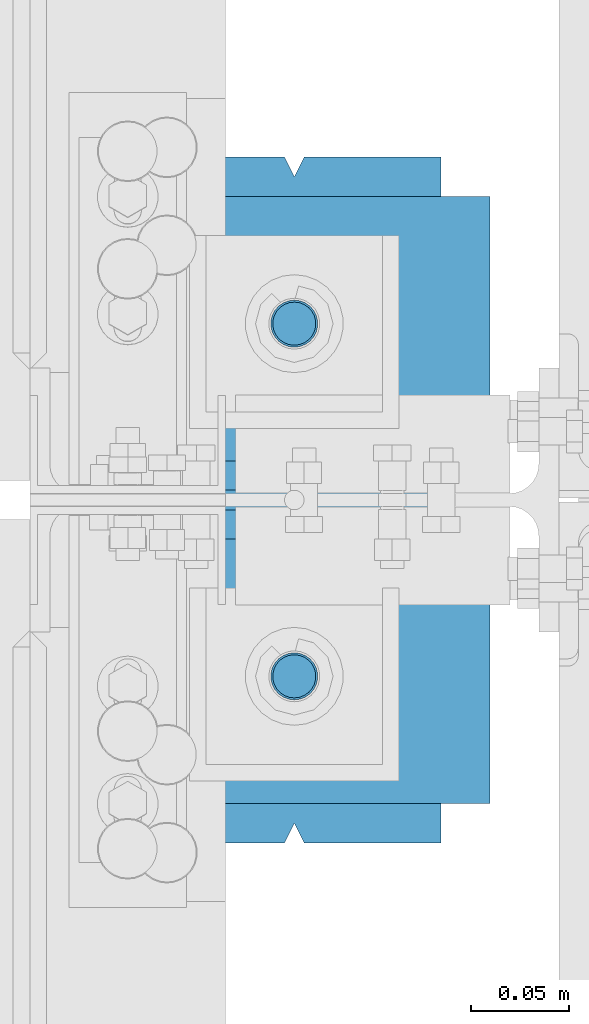
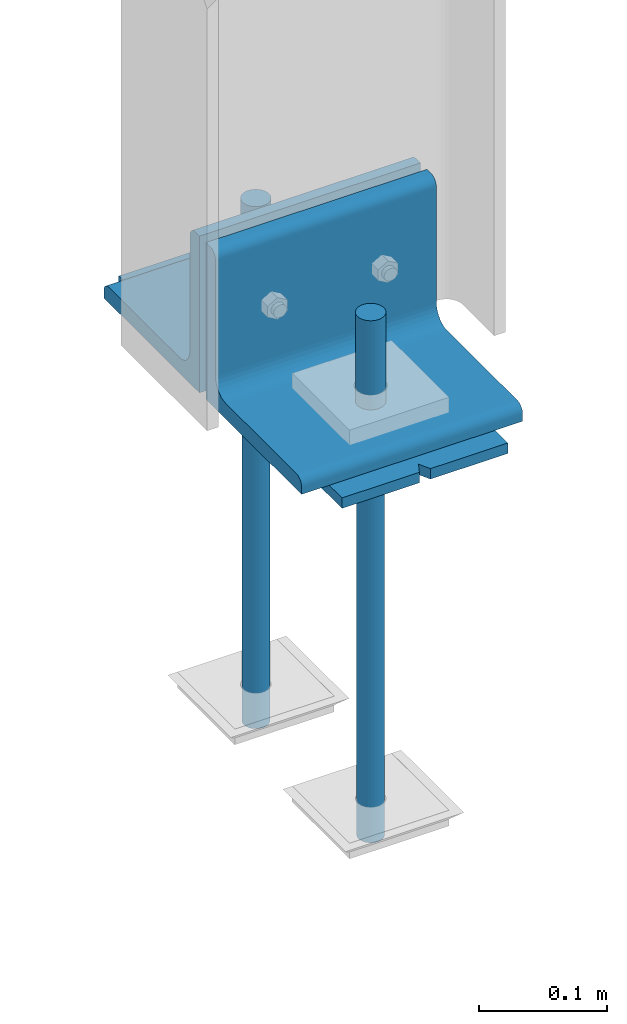
# One storey, part 73 of 496: 7 beams, 3 elements without a shape of their own.
"""IFC2X3 building model written with IfcOpenShell, lengths in millimetres."""

from ifc_helpers import new_model, si_unit, frame, origin_with_axes, origin_2d_with_axis, place, context, subcontext, project, spatial, polyline, rectangle, circle, l_section, outline, extrude, boolean, material, type_object, element, aggregate, save


model = new_model("IFC2X3")

# Units and contexts
model_context = context("Model", 3, precision=1e-05, world=origin_with_axes())
body_context = subcontext(model_context, "Body", "Model", "MODEL_VIEW")
ifc_project = project(units=[si_unit("LENGTHUNIT", "METRE", prefix="MILLI"), si_unit("AREAUNIT", "SQUARE_METRE"), si_unit("VOLUMEUNIT", "CUBIC_METRE"), si_unit("MASSUNIT", "GRAM", prefix="KILO"), si_unit("TIMEUNIT", "SECOND"), si_unit("PLANEANGLEUNIT", "RADIAN"), si_unit("SOLIDANGLEUNIT", "STERADIAN"), si_unit("THERMODYNAMICTEMPERATUREUNIT", "DEGREE_CELSIUS"), si_unit("LUMINOUSINTENSITYUNIT", "LUMEN")], contexts=[model_context])

# Site, building, storey
site_placement = place(None, origin_with_axes())
site = spatial("IfcSite", under=ifc_project, at=site_placement, CompositionType="ELEMENT")
building_placement = place(site_placement, origin_with_axes())
building = spatial("IfcBuilding", under=site, at=building_placement, Name="Undefined", CompositionType="ELEMENT")
storey_placement = place(building_placement, origin_with_axes())
storey = spatial("IfcBuildingStorey", under=building, at=storey_placement, Name="Undefined", CompositionType="ELEMENT", Elevation=0.0)

# Assembly, beams
assembly_1_placement = place(storey_placement, origin_with_axes())
assembly_1 = element("IfcElementAssembly", 1, at=assembly_1_placement, inside=storey, Name="PS24", AssemblyPlace="NOTDEFINED", PredefinedType="NOTDEFINED")
ifc_material = material(Name="Undefined/S235-E24")
beam_type_1 = type_object("IfcBeamType", Name="D24", PredefinedType="NOTDEFINED")
beam_1_placement = place(assembly_1_placement, frame((-45.0, 7509.99715044471, -100.0), z_axis=(-1.0, 0.0, 0.0), x_axis=(0.0, 0.0, -1.0)))
beam_1 = element("IfcBeam", 2, at=beam_1_placement, type_object=beam_type_1, material=ifc_material, ObjectType="D24", context=body_context, shape_type="SweptSolid", body=[
    extrude(circle(Radius=12.0, at=origin_2d_with_axis()), frame((149.999995982835, 4.54747350886464e-12, 3.63797880709171e-12), z_axis=(-1.0, 0.0, 0.0), x_axis=(0.0, -1.0, 0.0)), (0.0, 0.0, 1.0), 150.0),
])
beam_2_placement = place(assembly_1_placement, frame((-45.0, 7689.99715044471, -100.0), z_axis=(-1.0, 0.0, 0.0), x_axis=(0.0, 0.0, -1.0)))
beam_2 = element("IfcBeam", 3, at=beam_2_placement, type_object=beam_type_1, material=ifc_material, ObjectType="D24", context=body_context, shape_type="SweptSolid", body=[
    extrude(circle(Radius=12.0, at=origin_2d_with_axis()), frame((149.999995982835, 4.54747350886464e-12, 3.63797880709171e-12), z_axis=(-1.0, 0.0, 0.0), x_axis=(0.0, -1.0, 0.0)), (0.0, 0.0, 1.0), 150.0),
])
beam_type_2 = type_object("IfcBeamType", Name="D22", PredefinedType="NOTDEFINED")
beam_3_placement = place(assembly_1_placement, frame((-45.0, 7509.99715044471, -250.0), z_axis=(-1.0, 0.0, 0.0), x_axis=(0.0, 0.0, -1.0)))
beam_3 = element("IfcBeam", 4, at=beam_3_placement, type_object=beam_type_2, material=ifc_material, ObjectType="D22", context=body_context, shape_type="SweptSolid", body=[
    extrude(circle(Radius=11.0, at=origin_2d_with_axis()), frame((350.0, 0.0, 0.0), z_axis=(-1.0, 0.0, 0.0), x_axis=(0.0, -1.0, 0.0)), (0.0, 0.0, 1.0), 350.0),
])
beam_4_placement = place(assembly_1_placement, frame((-45.0, 7689.99715044471, -250.0), z_axis=(-1.0, 0.0, 0.0), x_axis=(0.0, 0.0, -1.0)))
beam_4 = element("IfcBeam", 5, at=beam_4_placement, type_object=beam_type_2, material=ifc_material, ObjectType="D22", context=body_context, shape_type="SweptSolid", body=[
    extrude(circle(Radius=11.0, at=origin_2d_with_axis()), frame((350.0, 0.0, 0.0), z_axis=(-1.0, 0.0, 0.0), x_axis=(0.0, -1.0, 0.0)), (0.0, 0.0, 1.0), 350.0),
])
beam_type_3 = type_object("IfcBeamType", PredefinedType="NOTDEFINED")
beam_5_placement = place(assembly_1_placement, frame((-45.0, 7775.0, -205.0), z_axis=(1.0, 0.0, 0.0), x_axis=(0.0, -1.0, 0.0)))
beam_5 = element("IfcBeam", 6, at=beam_5_placement, type_object=beam_type_3, material=ifc_material, Name="PS24", context=body_context, shape_type="CSG", body=[
    boolean("DIFFERENCE", boolean("DIFFERENCE", boolean("DIFFERENCE", boolean("DIFFERENCE", extrude(rectangle(XDim=10.0, YDim=150.0, at=origin_2d_with_axis()), frame((350.0, 0.0, 0.0), z_axis=(-1.0, 0.0, 0.0), x_axis=(0.0, -1.0, 0.0)), (0.0, 0.0, 1.0), 350.0), extrude(outline(polyline([(0.0, 0.0), (11.1803398132297, 1.2732925824821e-11), (4.47213602066586, 8.94427204135718), (0.0, 0.0)])), frame((0.0, 7.5, -5.0), z_axis=(0.0, -1.0, 0.0), x_axis=(0.894427191199935, 0.0, 0.44721359509992)), (0.0, 0.0, 1.0), 15.0)), extrude(outline(polyline([(0.0, 0.0), (11.1803398132297, 1.2732925824821e-11), (4.47213602066586, 8.94427204135718), (0.0, 0.0)])), frame((180.0, 7.5, -75.0), z_axis=(0.0, -1.0, 0.0), x_axis=(-0.447213595099959, 0.0, 0.894427191199915)), (0.0, 0.0, 1.0), 15.0)), extrude(outline(polyline([(0.0, 0.0), (11.1803398132297, 1.2732925824821e-11), (6.70820379256475, 8.94427204134627), (0.0, 0.0)])), frame((340.0, 7.5, 0.0), z_axis=(0.0, -1.0, 0.0), x_axis=(0.894427191199935, 0.0, -0.44721359509992)), (0.0, 0.0, 1.0), 15.0)), extrude(outline(polyline([(0.0, 0.0), (11.1803398132297, 1.2732925824821e-11), (4.47213602066586, 8.94427204135718), (0.0, 0.0)])), frame((170.0, 7.5, 75.0), z_axis=(0.0, -1.0, 0.0), x_axis=(0.447213595099959, 0.0, -0.894427191199915)), (0.0, 0.0, 1.0), 15.0)),
])
aggregate(assembly_1, [beam_1, beam_3, beam_2, beam_4, beam_5])

# Assembly, beam
assembly_2_placement = place(storey_placement, origin_with_axes())
assembly_2 = element("IfcElementAssembly", 7, at=assembly_2_placement, inside=storey, AssemblyPlace="NOTDEFINED", PredefinedType="NOTDEFINED")
beam_type_4 = type_object("IfcBeamType", PredefinedType="NOTDEFINED")
beam_6_placement = place(assembly_2_placement, frame((55.0, 7680.0, -125.0), z_axis=(0.0, 0.0, 1.0), x_axis=(-1.0, 0.0, 0.0)))
beam_6 = element("IfcBeam", 8, at=beam_6_placement, type_object=beam_type_4, material=ifc_material, context=body_context, shape_type="SweptSolid", body=[
    extrude(l_section(Depth=150.0, Width=150.0, Thickness=15.0, FilletRadius=16.0, EdgeRadius=8.0, at=origin_2d_with_axis()), frame((200.0, 0.0, 0.0), z_axis=(-1.0, 0.0, 0.0), x_axis=(0.0, -1.0, 0.0)), (0.0, 0.0, 1.0), 200.0),
])
aggregate(assembly_2, [beam_6])

assembly_3_placement = place(storey_placement, origin_with_axes())
assembly_3 = element("IfcElementAssembly", 9, at=assembly_3_placement, inside=storey, AssemblyPlace="NOTDEFINED", PredefinedType="NOTDEFINED")
beam_7_placement = place(assembly_3_placement, frame((-145.0, 7520.0, -125.0), z_axis=(0.0, 0.0, 1.0), x_axis=(1.0, 0.0, 0.0)))
beam_7 = element("IfcBeam", 10, at=beam_7_placement, type_object=beam_type_4, material=ifc_material, context=body_context, shape_type="SweptSolid", body=[
    extrude(l_section(Depth=150.0, Width=150.0, Thickness=15.0, FilletRadius=16.0, EdgeRadius=8.0, at=origin_2d_with_axis()), frame((200.0, 0.0, 0.0), z_axis=(-1.0, 0.0, 0.0), x_axis=(0.0, -1.0, 0.0)), (0.0, 0.0, 1.0), 200.0),
])
aggregate(assembly_3, [beam_7])

save(model, "model.ifc")
